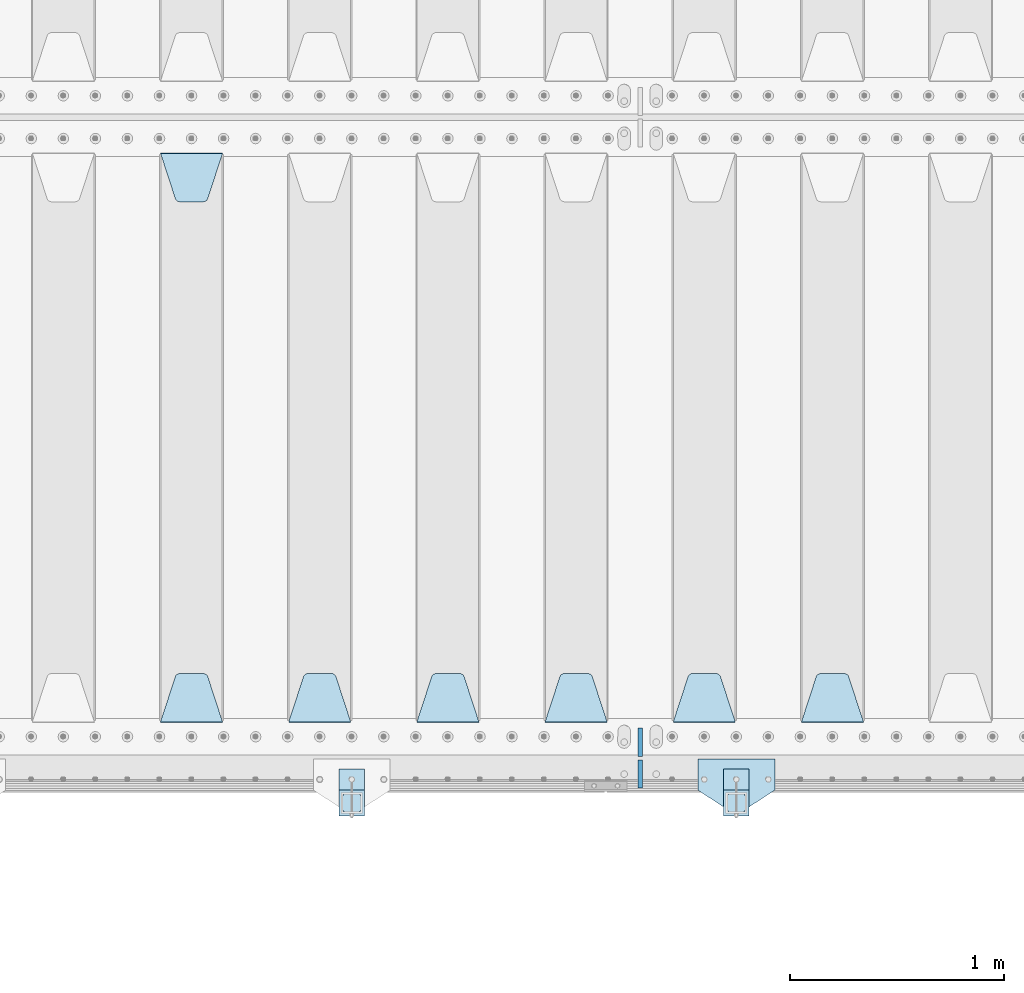
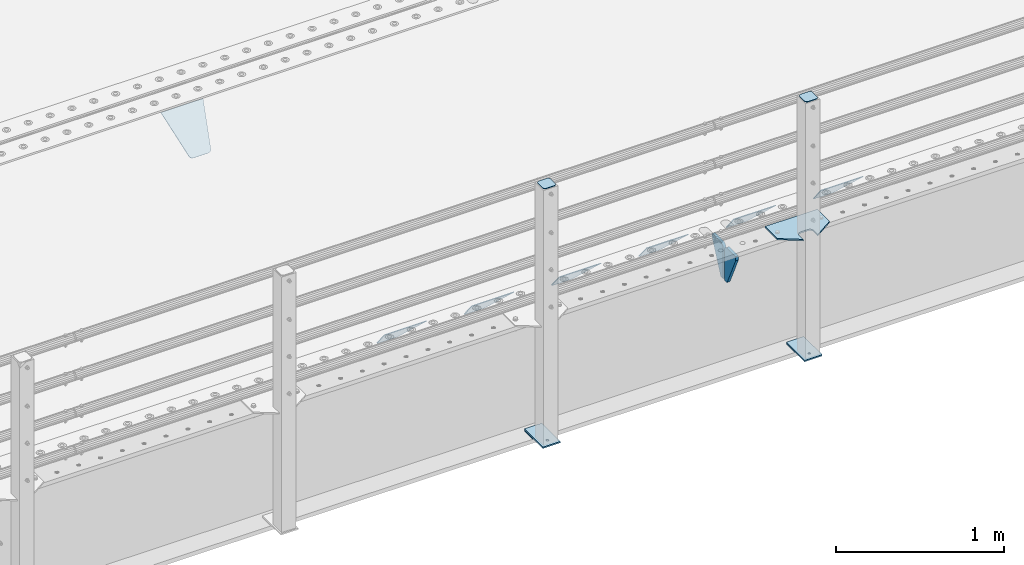
# One storey, part 204 of 257: 16 plates.
"""IFC2X3 building model written with IfcOpenShell, lengths in millimetres."""

from ifc_helpers import new_model, si_unit, frame, origin_with_axes, place, context, subcontext, project, spatial, faceted_brep, material, type_object, element, save


model = new_model("IFC2X3")

# Units and contexts
model_context = context("Model", 3, precision=1e-05, world=origin_with_axes())
body_context = subcontext(model_context, "Body", "Model", "MODEL_VIEW")
ifc_project = project(units=[si_unit("LENGTHUNIT", "METRE", prefix="MILLI"), si_unit("AREAUNIT", "SQUARE_METRE"), si_unit("VOLUMEUNIT", "CUBIC_METRE"), si_unit("MASSUNIT", "GRAM", prefix="KILO"), si_unit("TIMEUNIT", "SECOND"), si_unit("PLANEANGLEUNIT", "RADIAN"), si_unit("SOLIDANGLEUNIT", "STERADIAN"), si_unit("THERMODYNAMICTEMPERATUREUNIT", "DEGREE_CELSIUS"), si_unit("LUMINOUSINTENSITYUNIT", "LUMEN")], contexts=[model_context])

# Site, building, storey
site_placement = place(None, origin_with_axes())
site = spatial("IfcSite", under=ifc_project, at=site_placement, CompositionType="ELEMENT")
building_placement = place(site_placement, origin_with_axes())
building = spatial("IfcBuilding", under=site, at=building_placement, Name="Standard", CompositionType="ELEMENT")
storey_placement = place(building_placement, origin_with_axes())
storey = spatial("IfcBuildingStorey", under=building, at=storey_placement, Name="Undefined", CompositionType="ELEMENT", Elevation=0.0)

# Plates
ifc_material_1 = material(Name="STEEL/S355N")
plate_type_1 = type_object("IfcPlateType", PredefinedType="NOTDEFINED")
plate_1_placement = place(storey_placement, frame((48995.0, 168.232233047034, -1.76776695296758), z_axis=(0.0, 0.707106781186547, -0.707106781186548), x_axis=(-1.0, 0.0, 0.0)))
element("IfcPlate", 1, at=plate_1_placement, inside=storey, type_object=plate_type_1, material=ifc_material_1, context=body_context, shape_type="Brep", body=[
    faceted_brep([(0.0, -2.5, 0.0), (69.345504679477, -2.50000000000091, 300.17173142483), (69.345504679477, 2.5, 300.171731424831), (0.0, 2.5, 0.0), (70.927406119954, -2.50000000000091, 304.8974424154), (70.927406119954, 2.5, 304.8974424154), (73.3818627772271, -2.50000000000091, 309.234538108527), (73.3818627772271, 2.49999999999909, 309.234538108527), (76.6187032999587, -2.5, 313.023683126103), (76.6187032999587, 2.5, 313.023683126103), (80.5190132705029, -2.5, 316.125672595372), (80.5190132705029, 2.5, 316.125672595371), (84.9395038596849, -2.5, 318.426546230476), (84.9395038596849, 2.5, 318.426546230477), (89.7177759439219, -2.5, 319.841774983275), (89.7177759439219, 2.5, 319.841774983275), (94.6782862926484, -2.5, 320.319366455079), (94.6782862926484, 2.5, 320.319366455079), (195.321713707352, -2.5, 320.319366455079), (195.321713707352, 2.5, 320.319366455079), (200.282224056078, -2.5, 319.841774983275), (200.282224056078, 2.49999999999909, 319.841774983275), (205.060496140315, -2.5, 318.426546230476), (205.060496140315, 2.49999999999909, 318.426546230475), (209.480986729497, -2.5, 316.125672595371), (209.480986729497, 2.5, 316.125672595371), (213.381296700041, -2.50000000000091, 313.023683126102), (213.381296700041, 2.5, 313.023683126103), (216.618137222766, -2.50000000000091, 309.234538108527), (216.618137222766, 2.5, 309.234538108527), (219.072593880039, -2.5, 304.897442415399), (219.072593880039, 2.5, 304.897442415399), (220.654495320523, -2.50000000000091, 300.17173142483), (220.654495320523, 2.5, 300.171731424831), (290.0, -2.50000000000091, 0.0), (290.0, 2.5, 9.09494701772928e-13)], [[[0, 1, 2, 3]], [[1, 4, 5, 2]], [[4, 6, 7, 5]], [[6, 8, 9, 7]], [[8, 10, 11, 9]], [[10, 12, 13, 11]], [[12, 14, 15, 13]], [[14, 16, 17, 15]], [[16, 18, 19, 17]], [[18, 20, 21, 19]], [[20, 22, 23, 21]], [[22, 24, 25, 23]], [[24, 26, 27, 25]], [[26, 28, 29, 27]], [[28, 30, 31, 29]], [[30, 32, 33, 31]], [[32, 34, 35, 33]], [[34, 0, 3, 35]], [[5, 7, 9, 11, 13, 15, 17, 19, 21, 23, 25, 27, 29, 31, 33, 35, 3, 2]], [[34, 32, 30, 28, 26, 24, 22, 20, 18, 16, 14, 12, 10, 8, 6, 4, 1, 0]]]),
])
plate_2_placement = place(storey_placement, frame((48395.0, 168.232233047034, -1.76776695296758), z_axis=(0.0, 0.707106781186547, -0.707106781186548), x_axis=(-1.0, 0.0, 0.0)))
element("IfcPlate", 2, at=plate_2_placement, inside=storey, type_object=plate_type_1, material=ifc_material_1, context=body_context, shape_type="Brep", body=[
    faceted_brep([(0.0, -2.5, 0.0), (69.345504679477, -2.50000000000091, 300.17173142483), (69.345504679477, 2.5, 300.171731424831), (0.0, 2.5, 0.0), (70.927406119954, -2.50000000000091, 304.8974424154), (70.927406119954, 2.5, 304.8974424154), (73.3818627772271, -2.50000000000091, 309.234538108527), (73.3818627772271, 2.49999999999909, 309.234538108527), (76.6187032999587, -2.5, 313.023683126103), (76.6187032999587, 2.5, 313.023683126103), (80.5190132705029, -2.5, 316.125672595372), (80.5190132705029, 2.5, 316.125672595371), (84.9395038596849, -2.5, 318.426546230476), (84.9395038596849, 2.5, 318.426546230477), (89.7177759439219, -2.5, 319.841774983275), (89.7177759439219, 2.5, 319.841774983275), (94.6782862926484, -2.5, 320.319366455079), (94.6782862926484, 2.5, 320.319366455079), (195.321713707352, -2.5, 320.319366455079), (195.321713707352, 2.5, 320.319366455079), (200.282224056078, -2.5, 319.841774983275), (200.282224056078, 2.49999999999909, 319.841774983275), (205.060496140315, -2.5, 318.426546230476), (205.060496140315, 2.49999999999909, 318.426546230475), (209.480986729497, -2.5, 316.125672595371), (209.480986729497, 2.5, 316.125672595371), (213.381296700041, -2.50000000000091, 313.023683126102), (213.381296700041, 2.5, 313.023683126103), (216.618137222766, -2.50000000000091, 309.234538108527), (216.618137222766, 2.5, 309.234538108527), (219.072593880039, -2.5, 304.897442415399), (219.072593880039, 2.5, 304.897442415399), (220.654495320523, -2.50000000000091, 300.17173142483), (220.654495320523, 2.5, 300.171731424831), (290.0, -2.50000000000091, 0.0), (290.0, 2.5, 9.09494701772928e-13)], [[[0, 1, 2, 3]], [[1, 4, 5, 2]], [[4, 6, 7, 5]], [[6, 8, 9, 7]], [[8, 10, 11, 9]], [[10, 12, 13, 11]], [[12, 14, 15, 13]], [[14, 16, 17, 15]], [[16, 18, 19, 17]], [[18, 20, 21, 19]], [[20, 22, 23, 21]], [[22, 24, 25, 23]], [[24, 26, 27, 25]], [[26, 28, 29, 27]], [[28, 30, 31, 29]], [[30, 32, 33, 31]], [[32, 34, 35, 33]], [[34, 0, 3, 35]], [[5, 7, 9, 11, 13, 15, 17, 19, 21, 23, 25, 27, 29, 31, 33, 35, 3, 2]], [[34, 32, 30, 28, 26, 24, 22, 20, 18, 16, 14, 12, 10, 8, 6, 4, 1, 0]]]),
])
plate_3_placement = place(storey_placement, frame((47795.0, 168.232233047034, -1.76776695296758), z_axis=(0.0, 0.707106781186547, -0.707106781186548), x_axis=(-1.0, 0.0, 0.0)))
element("IfcPlate", 3, at=plate_3_placement, inside=storey, type_object=plate_type_1, material=ifc_material_1, context=body_context, shape_type="Brep", body=[
    faceted_brep([(0.0, -2.5, 0.0), (69.345504679477, -2.50000000000091, 300.17173142483), (69.345504679477, 2.5, 300.171731424831), (0.0, 2.5, 0.0), (70.927406119954, -2.50000000000091, 304.8974424154), (70.927406119954, 2.5, 304.8974424154), (73.3818627772271, -2.50000000000091, 309.234538108527), (73.3818627772271, 2.49999999999909, 309.234538108527), (76.6187032999587, -2.5, 313.023683126103), (76.6187032999587, 2.5, 313.023683126103), (80.5190132705029, -2.5, 316.125672595372), (80.5190132705029, 2.5, 316.125672595371), (84.9395038596849, -2.5, 318.426546230476), (84.9395038596849, 2.5, 318.426546230477), (89.7177759439219, -2.5, 319.841774983275), (89.7177759439219, 2.5, 319.841774983275), (94.6782862926484, -2.5, 320.319366455079), (94.6782862926484, 2.5, 320.319366455079), (195.321713707352, -2.5, 320.319366455079), (195.321713707352, 2.5, 320.319366455079), (200.282224056078, -2.5, 319.841774983275), (200.282224056078, 2.49999999999909, 319.841774983275), (205.060496140315, -2.5, 318.426546230476), (205.060496140315, 2.49999999999909, 318.426546230475), (209.480986729497, -2.5, 316.125672595371), (209.480986729497, 2.5, 316.125672595371), (213.381296700041, -2.50000000000091, 313.023683126102), (213.381296700041, 2.5, 313.023683126103), (216.618137222766, -2.50000000000091, 309.234538108527), (216.618137222766, 2.5, 309.234538108527), (219.072593880039, -2.5, 304.897442415399), (219.072593880039, 2.5, 304.897442415399), (220.654495320523, -2.50000000000091, 300.17173142483), (220.654495320523, 2.5, 300.171731424831), (290.0, -2.50000000000091, 0.0), (290.0, 2.5, 9.09494701772928e-13)], [[[0, 1, 2, 3]], [[1, 4, 5, 2]], [[4, 6, 7, 5]], [[6, 8, 9, 7]], [[8, 10, 11, 9]], [[10, 12, 13, 11]], [[12, 14, 15, 13]], [[14, 16, 17, 15]], [[16, 18, 19, 17]], [[18, 20, 21, 19]], [[20, 22, 23, 21]], [[22, 24, 25, 23]], [[24, 26, 27, 25]], [[26, 28, 29, 27]], [[28, 30, 31, 29]], [[30, 32, 33, 31]], [[32, 34, 35, 33]], [[34, 0, 3, 35]], [[5, 7, 9, 11, 13, 15, 17, 19, 21, 23, 25, 27, 29, 31, 33, 35, 3, 2]], [[34, 32, 30, 28, 26, 24, 22, 20, 18, 16, 14, 12, 10, 8, 6, 4, 1, 0]]]),
])
plate_4_placement = place(storey_placement, frame((47195.0, 168.232233047034, -1.76776695296758), z_axis=(0.0, 0.707106781186547, -0.707106781186548), x_axis=(-1.0, 0.0, 0.0)))
element("IfcPlate", 4, at=plate_4_placement, inside=storey, type_object=plate_type_1, material=ifc_material_1, context=body_context, shape_type="Brep", body=[
    faceted_brep([(0.0, -2.5, 0.0), (69.345504679477, -2.50000000000091, 300.17173142483), (69.345504679477, 2.5, 300.171731424831), (0.0, 2.5, 0.0), (70.927406119954, -2.50000000000091, 304.8974424154), (70.927406119954, 2.5, 304.8974424154), (73.3818627772271, -2.50000000000091, 309.234538108527), (73.3818627772271, 2.49999999999909, 309.234538108527), (76.6187032999587, -2.5, 313.023683126103), (76.6187032999587, 2.5, 313.023683126103), (80.5190132705029, -2.5, 316.125672595372), (80.5190132705029, 2.5, 316.125672595371), (84.9395038596849, -2.5, 318.426546230476), (84.9395038596849, 2.5, 318.426546230477), (89.7177759439219, -2.5, 319.841774983275), (89.7177759439219, 2.5, 319.841774983275), (94.6782862926484, -2.5, 320.319366455079), (94.6782862926484, 2.5, 320.319366455079), (195.321713707352, -2.5, 320.319366455079), (195.321713707352, 2.5, 320.319366455079), (200.282224056078, -2.5, 319.841774983275), (200.282224056078, 2.49999999999909, 319.841774983275), (205.060496140315, -2.5, 318.426546230476), (205.060496140315, 2.49999999999909, 318.426546230475), (209.480986729497, -2.5, 316.125672595371), (209.480986729497, 2.5, 316.125672595371), (213.381296700041, -2.50000000000091, 313.023683126102), (213.381296700041, 2.5, 313.023683126103), (216.618137222766, -2.50000000000091, 309.234538108527), (216.618137222766, 2.5, 309.234538108527), (219.072593880039, -2.5, 304.897442415399), (219.072593880039, 2.5, 304.897442415399), (220.654495320523, -2.50000000000091, 300.17173142483), (220.654495320523, 2.5, 300.171731424831), (290.0, -2.50000000000091, 0.0), (290.0, 2.5, 9.09494701772928e-13)], [[[0, 1, 2, 3]], [[1, 4, 5, 2]], [[4, 6, 7, 5]], [[6, 8, 9, 7]], [[8, 10, 11, 9]], [[10, 12, 13, 11]], [[12, 14, 15, 13]], [[14, 16, 17, 15]], [[16, 18, 19, 17]], [[18, 20, 21, 19]], [[20, 22, 23, 21]], [[22, 24, 25, 23]], [[24, 26, 27, 25]], [[26, 28, 29, 27]], [[28, 30, 31, 29]], [[30, 32, 33, 31]], [[32, 34, 35, 33]], [[34, 0, 3, 35]], [[5, 7, 9, 11, 13, 15, 17, 19, 21, 23, 25, 27, 29, 31, 33, 35, 3, 2]], [[34, 32, 30, 28, 26, 24, 22, 20, 18, 16, 14, 12, 10, 8, 6, 4, 1, 0]]]),
])
plate_5_placement = place(storey_placement, frame((46595.0, 168.232233047034, -1.76776695296758), z_axis=(0.0, 0.707106781186547, -0.707106781186548), x_axis=(-1.0, 0.0, 0.0)))
element("IfcPlate", 5, at=plate_5_placement, inside=storey, type_object=plate_type_1, material=ifc_material_1, context=body_context, shape_type="Brep", body=[
    faceted_brep([(0.0, -2.5, 0.0), (69.345504679477, -2.50000000000091, 300.17173142483), (69.345504679477, 2.5, 300.171731424831), (0.0, 2.5, 0.0), (70.927406119954, -2.50000000000091, 304.8974424154), (70.927406119954, 2.5, 304.8974424154), (73.3818627772271, -2.50000000000091, 309.234538108527), (73.3818627772271, 2.49999999999909, 309.234538108527), (76.6187032999587, -2.5, 313.023683126103), (76.6187032999587, 2.5, 313.023683126103), (80.5190132705029, -2.5, 316.125672595372), (80.5190132705029, 2.5, 316.125672595371), (84.9395038596849, -2.5, 318.426546230476), (84.9395038596849, 2.5, 318.426546230477), (89.7177759439219, -2.5, 319.841774983275), (89.7177759439219, 2.5, 319.841774983275), (94.6782862926484, -2.5, 320.319366455079), (94.6782862926484, 2.5, 320.319366455079), (195.321713707352, -2.5, 320.319366455079), (195.321713707352, 2.5, 320.319366455079), (200.282224056078, -2.5, 319.841774983275), (200.282224056078, 2.49999999999909, 319.841774983275), (205.060496140315, -2.5, 318.426546230476), (205.060496140315, 2.49999999999909, 318.426546230475), (209.480986729497, -2.5, 316.125672595371), (209.480986729497, 2.5, 316.125672595371), (213.381296700041, -2.50000000000091, 313.023683126102), (213.381296700041, 2.5, 313.023683126103), (216.618137222766, -2.50000000000091, 309.234538108527), (216.618137222766, 2.5, 309.234538108527), (219.072593880039, -2.5, 304.897442415399), (219.072593880039, 2.5, 304.897442415399), (220.654495320523, -2.50000000000091, 300.17173142483), (220.654495320523, 2.5, 300.171731424831), (290.0, -2.50000000000091, 0.0), (290.0, 2.5, 9.09494701772928e-13)], [[[0, 1, 2, 3]], [[1, 4, 5, 2]], [[4, 6, 7, 5]], [[6, 8, 9, 7]], [[8, 10, 11, 9]], [[10, 12, 13, 11]], [[12, 14, 15, 13]], [[14, 16, 17, 15]], [[16, 18, 19, 17]], [[18, 20, 21, 19]], [[20, 22, 23, 21]], [[22, 24, 25, 23]], [[24, 26, 27, 25]], [[26, 28, 29, 27]], [[28, 30, 31, 29]], [[30, 32, 33, 31]], [[32, 34, 35, 33]], [[34, 0, 3, 35]], [[5, 7, 9, 11, 13, 15, 17, 19, 21, 23, 25, 27, 29, 31, 33, 35, 3, 2]], [[34, 32, 30, 28, 26, 24, 22, 20, 18, 16, 14, 12, 10, 8, 6, 4, 1, 0]]]),
])
plate_6_placement = place(storey_placement, frame((45705.0, 2831.76776695594, -1.767766952965), z_axis=(0.0, -0.707106781186548, -0.707106781186547), x_axis=(1.0, 0.0, 0.0)))
element("IfcPlate", 6, at=plate_6_placement, inside=storey, type_object=plate_type_1, material=ifc_material_1, context=body_context, shape_type="Brep", body=[
    faceted_brep([(0.0, -2.5, 0.0), (69.345504679477, -2.50000000000091, 300.17173142483), (69.345504679477, 2.5, 300.171731424831), (0.0, 2.5, 0.0), (70.927406119954, -2.50000000000091, 304.8974424154), (70.927406119954, 2.5, 304.8974424154), (73.3818627772271, -2.50000000000091, 309.234538108527), (73.3818627772271, 2.49999999999909, 309.234538108527), (76.6187032999587, -2.5, 313.023683126103), (76.6187032999587, 2.5, 313.023683126103), (80.5190132705029, -2.5, 316.125672595372), (80.5190132705029, 2.5, 316.125672595371), (84.9395038596849, -2.5, 318.426546230476), (84.9395038596849, 2.5, 318.426546230477), (89.7177759439219, -2.5, 319.841774983275), (89.7177759439219, 2.5, 319.841774983275), (94.6782862926484, -2.5, 320.319366455079), (94.6782862926484, 2.5, 320.319366455079), (195.321713707352, -2.5, 320.319366455079), (195.321713707352, 2.5, 320.319366455079), (200.282224056078, -2.5, 319.841774983275), (200.282224056078, 2.49999999999909, 319.841774983275), (205.060496140315, -2.5, 318.426546230476), (205.060496140315, 2.49999999999909, 318.426546230475), (209.480986729497, -2.5, 316.125672595371), (209.480986729497, 2.5, 316.125672595371), (213.381296700041, -2.50000000000091, 313.023683126102), (213.381296700041, 2.5, 313.023683126103), (216.618137222766, -2.50000000000091, 309.234538108527), (216.618137222766, 2.5, 309.234538108527), (219.072593880039, -2.5, 304.897442415399), (219.072593880039, 2.5, 304.897442415399), (220.654495320523, -2.50000000000091, 300.17173142483), (220.654495320523, 2.5, 300.171731424831), (290.0, -2.50000000000091, 0.0), (290.0, 2.5, 9.09494701772928e-13)], [[[0, 1, 2, 3]], [[1, 4, 5, 2]], [[4, 6, 7, 5]], [[6, 8, 9, 7]], [[8, 10, 11, 9]], [[10, 12, 13, 11]], [[12, 14, 15, 13]], [[14, 16, 17, 15]], [[16, 18, 19, 17]], [[18, 20, 21, 19]], [[20, 22, 23, 21]], [[22, 24, 25, 23]], [[24, 26, 27, 25]], [[26, 28, 29, 27]], [[28, 30, 31, 29]], [[30, 32, 33, 31]], [[32, 34, 35, 33]], [[34, 0, 3, 35]], [[5, 7, 9, 11, 13, 15, 17, 19, 21, 23, 25, 27, 29, 31, 33, 35, 3, 2]], [[34, 32, 30, 28, 26, 24, 22, 20, 18, 16, 14, 12, 10, 8, 6, 4, 1, 0]]]),
])
plate_7_placement = place(storey_placement, frame((45995.0, 168.232233047034, -1.76776695296758), z_axis=(0.0, 0.707106781186547, -0.707106781186548), x_axis=(-1.0, 0.0, 0.0)))
element("IfcPlate", 7, at=plate_7_placement, inside=storey, type_object=plate_type_1, material=ifc_material_1, context=body_context, shape_type="Brep", body=[
    faceted_brep([(0.0, -2.5, 0.0), (69.345504679477, -2.50000000000091, 300.17173142483), (69.345504679477, 2.5, 300.171731424831), (0.0, 2.5, 0.0), (70.927406119954, -2.50000000000091, 304.8974424154), (70.927406119954, 2.5, 304.8974424154), (73.3818627772271, -2.50000000000091, 309.234538108527), (73.3818627772271, 2.49999999999909, 309.234538108527), (76.6187032999587, -2.5, 313.023683126103), (76.6187032999587, 2.5, 313.023683126103), (80.5190132705029, -2.5, 316.125672595372), (80.5190132705029, 2.5, 316.125672595371), (84.9395038596849, -2.5, 318.426546230476), (84.9395038596849, 2.5, 318.426546230477), (89.7177759439219, -2.5, 319.841774983275), (89.7177759439219, 2.5, 319.841774983275), (94.6782862926484, -2.5, 320.319366455079), (94.6782862926484, 2.5, 320.319366455079), (195.321713707352, -2.5, 320.319366455079), (195.321713707352, 2.5, 320.319366455079), (200.282224056078, -2.5, 319.841774983275), (200.282224056078, 2.49999999999909, 319.841774983275), (205.060496140315, -2.5, 318.426546230476), (205.060496140315, 2.49999999999909, 318.426546230475), (209.480986729497, -2.5, 316.125672595371), (209.480986729497, 2.5, 316.125672595371), (213.381296700041, -2.50000000000091, 313.023683126102), (213.381296700041, 2.5, 313.023683126103), (216.618137222766, -2.50000000000091, 309.234538108527), (216.618137222766, 2.5, 309.234538108527), (219.072593880039, -2.5, 304.897442415399), (219.072593880039, 2.5, 304.897442415399), (220.654495320523, -2.50000000000091, 300.17173142483), (220.654495320523, 2.5, 300.171731424831), (290.0, -2.50000000000091, 0.0), (290.0, 2.5, 9.09494701772928e-13)], [[[0, 1, 2, 3]], [[1, 4, 5, 2]], [[4, 6, 7, 5]], [[6, 8, 9, 7]], [[8, 10, 11, 9]], [[10, 12, 13, 11]], [[12, 14, 15, 13]], [[14, 16, 17, 15]], [[16, 18, 19, 17]], [[18, 20, 21, 19]], [[20, 22, 23, 21]], [[22, 24, 25, 23]], [[24, 26, 27, 25]], [[26, 28, 29, 27]], [[28, 30, 31, 29]], [[30, 32, 33, 31]], [[32, 34, 35, 33]], [[34, 0, 3, 35]], [[5, 7, 9, 11, 13, 15, 17, 19, 21, 23, 25, 27, 29, 31, 33, 35, 3, 2]], [[34, 32, 30, 28, 26, 24, 22, 20, 18, 16, 14, 12, 10, 8, 6, 4, 1, 0]]]),
])
plate_type_2 = type_object("IfcPlateType", PredefinedType="NOTDEFINED")
for number, where, z_axis, x_axis in (
    (8, (47950.0, 140.0, -30.0), (0.0, 0.0, -1.0), (0.0, -1.0, 0.0)),
    (9, (47950.0, -140.0, -30.0), (0.0, 0.0, -1.0), (0.0, 1.0, 0.0)),
):
    element("IfcPlate", number, at=place(storey_placement, frame(where, z_axis=z_axis, x_axis=x_axis)), inside=storey, type_object=plate_type_2, material=ifc_material_1, context=body_context, shape_type="Brep", body=[
        faceted_brep([(0.0, -10.0, 0.0), (0.0, -10.0, 30.0), (0.0, 10.0, 30.0), (0.0, 10.0, 0.0), (102.0, -10.0, 250.0), (102.0, 10.0, 250.0), (132.0, -10.0, 250.0), (132.0, 10.0, 250.0), (132.0, -10.0, 30.0), (132.0, 10.0, 30.0), (131.544232590366, -10.0, 24.790554669992), (131.544232590366, 10.0, 24.790554669992), (130.190778623577, -10.0, 19.7393957002299), (130.190778623577, 10.0, 19.7393957002299), (127.980762113533, -10.0, 15.0), (127.980762113533, 10.0, 15.0), (124.981333293569, -10.0, 10.7163717094038), (124.981333293569, 10.0, 10.7163717094038), (121.283628290596, -10.0, 7.01866670643062), (121.283628290596, 10.0, 7.01866670643062), (117.0, -10.0, 4.01923788646684), (117.0, 10.0, 4.01923788646684), (112.26060429977, -10.0, 1.80922137642278), (112.26060429977, 10.0, 1.80922137642278), (107.209445330008, -10.0, 0.455767409633722), (107.209445330008, 10.0, 0.455767409633722), (102.0, -10.0, 0.0), (102.0, 10.0, 0.0)], [[[0, 1, 2, 3]], [[1, 4, 5, 2]], [[4, 6, 7, 5]], [[6, 8, 9, 7]], [[8, 10, 11, 9]], [[10, 12, 13, 11]], [[12, 14, 15, 13]], [[14, 16, 17, 15]], [[16, 18, 19, 17]], [[18, 20, 21, 19]], [[20, 22, 23, 21]], [[22, 24, 25, 23]], [[24, 26, 27, 25]], [[26, 0, 3, 27]], [[5, 7, 9, 11, 13, 15, 17, 19, 21, 23, 25, 27, 3, 2]], [[26, 24, 22, 20, 18, 16, 14, 12, 10, 8, 6, 4, 1, 0]]]),
    ])
ifc_material_2 = material(Name="STEEL/S355J2")
plate_type_3 = type_object("IfcPlateType", PredefinedType="NOTDEFINED")
plate_8_placement = place(storey_placement, frame((48580.0, -4.99999999999636, 5.00000000004911), z_axis=(0.0, -1.0, 0.0), x_axis=(-1.0, 0.0, 0.0)))
element("IfcPlate", 10, at=plate_8_placement, inside=storey, type_object=plate_type_3, material=ifc_material_2, context=body_context, shape_type="Brep", body=[
    faceted_brep([(0.0, -5.0, 0.0), (2.31396552408114e-06, -5.0, 145.0), (2.31396552408114e-06, 5.0, 145.0), (0.0, 5.0, 0.0), (130.0, -5.0, 230.0), (130.0, 5.0, 230.0), (130.0, -5.0, 180.0), (130.0, 5.0, 180.0), (130.48036798992, -5.0, 175.122741949597), (130.48036798992, 5.0, 175.122741949597), (131.903011687216, -5.0, 170.432914190873), (131.903011687216, 5.0, 170.432914190873), (134.213259692435, -5.0, 166.11074417451), (134.213259692435, 5.0, 166.11074417451), (137.322330470335, -5.0, 162.322330470337), (137.322330470335, 5.0, 162.322330470337), (141.110744174512, -5.0, 159.213259692437), (141.110744174512, 5.0, 159.213259692437), (145.432914190875, -5.0, 156.903011687218), (145.432914190875, 5.0, 156.903011687218), (150.122741949599, -5.0, 155.48036798992), (150.122741949599, 5.0, 155.48036798992), (155.0, -5.0, 155.0), (155.0, 5.0, 155.0), (205.0, -5.0, 155.0), (205.0, 5.0, 155.0), (209.877258050401, -5.0, 155.48036798992), (209.877258050401, 5.0, 155.48036798992), (214.567085809125, -5.0, 156.903011687218), (214.567085809125, 5.0, 156.903011687218), (218.889255825488, -5.0, 159.213259692437), (218.889255825488, 5.0, 159.213259692437), (222.677669529665, -5.0, 162.322330470337), (222.677669529665, 5.0, 162.322330470337), (225.786740307565, -5.0, 166.11074417451), (225.786740307565, 5.0, 166.11074417451), (228.096988312784, -5.0, 170.432914190873), (228.096988312784, 5.0, 170.432914190873), (229.51963201008, -5.0, 175.122741949597), (229.51963201008, 5.0, 175.122741949597), (230.0, -5.0, 180.0), (230.0, 5.0, 180.0), (230.0, -5.0, 230.0), (230.0, 5.0, 230.0), (360.0, -5.0, 145.0), (360.0, 5.0, 145.0), (360.0, -5.0, -7.27595761418343e-12), (360.0, 5.0, -7.27595761418343e-12)], [[[0, 1, 2, 3]], [[1, 4, 5, 2]], [[4, 6, 7, 5]], [[6, 8, 9, 7]], [[8, 10, 11, 9]], [[10, 12, 13, 11]], [[12, 14, 15, 13]], [[14, 16, 17, 15]], [[16, 18, 19, 17]], [[18, 20, 21, 19]], [[20, 22, 23, 21]], [[22, 24, 25, 23]], [[24, 26, 27, 25]], [[26, 28, 29, 27]], [[28, 30, 31, 29]], [[30, 32, 33, 31]], [[32, 34, 35, 33]], [[34, 36, 37, 35]], [[36, 38, 39, 37]], [[38, 40, 41, 39]], [[40, 42, 43, 41]], [[42, 44, 45, 43]], [[44, 46, 47, 45]], [[46, 0, 3, 47]], [[5, 7, 9, 11, 13, 15, 17, 19, 21, 23, 25, 27, 29, 31, 33, 35, 37, 39, 41, 43, 45, 47, 3, 2]], [[46, 44, 42, 40, 38, 36, 34, 32, 30, 28, 26, 24, 22, 20, 18, 16, 14, 12, 10, 8, 6, 4, 1, 0]]]),
])
plate_type_4 = type_object("IfcPlateType", PredefinedType="NOTDEFINED")
for number, where, z_axis, x_axis in (
    (11, (48459.9999999999, -50.0000000002074, -850.000000000002), (0.0, -1.0, 0.0), (-1.0, 0.0, 0.0)),
    (12, (46659.9999999999, -50.0000000002074, -850.000000000002), (0.0, -1.0, 0.0), (-1.0, 0.0, 0.0)),
):
    element("IfcPlate", number, at=place(storey_placement, frame(where, z_axis=z_axis, x_axis=x_axis)), inside=storey, type_object=plate_type_4, material=ifc_material_2, context=body_context, shape_type="Brep", body=[
        faceted_brep([(53.6360389691836, -5.0, 176.363961030469), (53.6360389691836, 5.0, 176.363961030469), (59.9999999998618, 5.0, 178.999999999791), (59.9999999998618, -5.0, 178.999999999791), (66.3639610305399, 5.0, 176.363961030469), (66.3639610305399, -5.0, 176.363961030469), (68.9999999998618, 5.0, 169.999999999791), (68.9999999998618, -5.0, 169.999999999791), (66.3639610305399, 5.0, 163.636038969113), (66.3639610305399, -5.0, 163.636038969113), (59.9999999998618, 5.0, 160.999999999791), (59.9999999998618, -5.0, 160.999999999791), (53.6360389691836, 5.0, 163.636038969113), (53.6360389691836, -5.0, 163.636038969113), (50.9999999998618, 5.0, 169.999999999791), (50.9999999998618, -5.0, 169.999999999791), (120.0, -5.0, 0.0), (120.0, -5.0, 220.0), (0.0, -5.0, 220.0), (0.0, -5.0, 0.0), (0.0, 5.0, 0.0), (120.0, 5.0, 0.0), (120.0, 5.0, 220.0), (0.0, 5.0, 220.0)], [[[0, 1, 2, 3]], [[3, 2, 4, 5]], [[5, 4, 6, 7]], [[7, 6, 8, 9]], [[9, 8, 10, 11]], [[11, 10, 12, 13]], [[13, 12, 14, 15]], [[15, 14, 1, 0]], [[16, 17, 18, 19], [11, 13, 15, 0, 3, 5, 7, 9]], [[16, 19, 20, 21]], [[17, 16, 21, 22]], [[18, 17, 22, 23]], [[19, 18, 23, 20]], [[22, 21, 20, 23], [2, 1, 14, 12, 10, 8, 6, 4]]]),
    ])
plate_type_5 = type_object("IfcPlateType", PredefinedType="NOTDEFINED")
plate_9_placement = place(storey_placement, frame((48355.9999999999, -166.000000000207, 1012.50000000001), z_axis=(0.0, -1.0, 0.0), x_axis=(1.0, 0.0, 0.0)))
element("IfcPlate", 13, at=plate_9_placement, inside=storey, type_object=plate_type_5, material=ifc_material_2, context=body_context, shape_type="Brep", body=[
    faceted_brep([(0.0, -2.5, 19.0), (0.0, -2.5, 69.0), (0.0, 2.5, 69.0), (0.0, 2.5, 19.0), (0.476369668547704, -2.5, 73.2278977451697), (0.476369668547704, 2.5, 73.2278977451697), (1.88159150985302, -2.5, 77.2437910432327), (1.88159150985302, 2.5, 77.2437910432327), (4.14520183311106, -2.5, 80.8463062353167), (4.14520183311106, 2.5, 80.8463062353167), (7.15369376468152, -2.5, 83.8547981668926), (7.15369376468152, 2.5, 83.8547981668926), (10.7562089567655, -2.5, 86.1184084901452), (10.7562089567655, 2.5, 86.1184084901452), (14.7721022548285, -2.5, 87.5236303314541), (14.7721022548285, 2.5, 87.5236303314541), (19.0, -2.5, 88.0), (19.0, 2.5, 88.0), (69.0, -2.5, 88.0), (69.0, 2.5, 88.0), (73.2278977451715, -2.5, 87.5236303314541), (73.2278977451715, 2.5, 87.5236303314541), (77.2437910432345, -2.5, 86.1184084901452), (77.2437910432345, 2.5, 86.1184084901452), (80.8463062353185, -2.5, 83.8547981668926), (80.8463062353185, 2.5, 83.8547981668926), (83.8547981668889, -2.5, 80.8463062353167), (83.8547981668889, 2.5, 80.8463062353167), (86.118408490147, -2.5, 77.2437910432327), (86.118408490147, 2.5, 77.2437910432327), (87.5236303314523, -2.5, 73.2278977451697), (87.5236303314523, 2.5, 73.2278977451697), (88.0, -2.5, 69.0), (88.0, 2.5, 69.0), (88.0, -2.5, 19.0), (88.0, 2.5, 19.0), (87.5236303314523, -2.5, 14.7721022548303), (87.5236303314523, 2.5, 14.7721022548303), (86.118408490147, -2.5, 10.7562089567673), (86.118408490147, 2.5, 10.7562089567673), (83.8547981668889, -2.5, 7.15369376468334), (83.8547981668889, 2.5, 7.15369376468334), (80.8463062353185, -2.5, 4.14520183310742), (80.8463062353185, 2.5, 4.14520183310742), (77.2437910432345, -2.5, 1.88159150985484), (77.2437910432345, 2.5, 1.88159150985484), (73.2278977451715, -2.5, 0.476369668545885), (73.2278977451715, 2.5, 0.476369668545885), (69.0, -2.5, 0.0), (69.0, 2.5, 0.0), (19.0, -2.5, 0.0), (19.0, 2.5, 0.0), (14.7721022548285, -2.5, 0.476369668545885), (14.7721022548285, 2.5, 0.476369668545885), (10.7562089567655, -2.5, 1.88159150985484), (10.7562089567655, 2.5, 1.88159150985484), (7.15369376468152, -2.5, 4.14520183310742), (7.15369376468152, 2.5, 4.14520183310742), (4.14520183311106, -2.5, 7.15369376468334), (4.14520183311106, 2.5, 7.15369376468334), (1.88159150985302, -2.5, 10.7562089567673), (1.88159150985302, 2.5, 10.7562089567673), (0.476369668547704, -2.5, 14.7721022548303), (0.476369668547704, 2.5, 14.7721022548303)], [[[0, 1, 2, 3]], [[1, 4, 5, 2]], [[4, 6, 7, 5]], [[6, 8, 9, 7]], [[8, 10, 11, 9]], [[10, 12, 13, 11]], [[12, 14, 15, 13]], [[14, 16, 17, 15]], [[16, 18, 19, 17]], [[18, 20, 21, 19]], [[20, 22, 23, 21]], [[22, 24, 25, 23]], [[24, 26, 27, 25]], [[26, 28, 29, 27]], [[28, 30, 31, 29]], [[30, 32, 33, 31]], [[32, 34, 35, 33]], [[34, 36, 37, 35]], [[36, 38, 39, 37]], [[38, 40, 41, 39]], [[40, 42, 43, 41]], [[42, 44, 45, 43]], [[44, 46, 47, 45]], [[46, 48, 49, 47]], [[48, 50, 51, 49]], [[50, 52, 53, 51]], [[52, 54, 55, 53]], [[54, 56, 57, 55]], [[56, 58, 59, 57]], [[58, 60, 61, 59]], [[60, 62, 63, 61]], [[62, 0, 3, 63]], [[5, 7, 9, 11, 13, 15, 17, 19, 21, 23, 25, 27, 29, 31, 33, 35, 37, 39, 41, 43, 45, 47, 49, 51, 53, 55, 57, 59, 61, 63, 3, 2]], [[62, 60, 58, 56, 54, 52, 50, 48, 46, 44, 42, 40, 38, 36, 34, 32, 30, 28, 26, 24, 22, 20, 18, 16, 14, 12, 10, 8, 6, 4, 1, 0]]]),
])
plate_10_placement = place(storey_placement, frame((46555.9999999999, -166.000000000207, 1012.50000000001), z_axis=(0.0, -1.0, 0.0), x_axis=(1.0, 0.0, 0.0)))
element("IfcPlate", 14, at=plate_10_placement, inside=storey, type_object=plate_type_5, material=ifc_material_2, context=body_context, shape_type="Brep", body=[
    faceted_brep([(0.0, -2.5, 19.0), (0.0, -2.5, 69.0), (0.0, 2.5, 69.0), (0.0, 2.5, 19.0), (0.476369668547704, -2.5, 73.2278977451697), (0.476369668547704, 2.5, 73.2278977451697), (1.88159150985302, -2.5, 77.2437910432327), (1.88159150985302, 2.5, 77.2437910432327), (4.14520183311106, -2.5, 80.8463062353167), (4.14520183311106, 2.5, 80.8463062353167), (7.15369376468152, -2.5, 83.8547981668926), (7.15369376468152, 2.5, 83.8547981668926), (10.7562089567655, -2.5, 86.1184084901452), (10.7562089567655, 2.5, 86.1184084901452), (14.7721022548285, -2.5, 87.5236303314541), (14.7721022548285, 2.5, 87.5236303314541), (19.0, -2.5, 88.0), (19.0, 2.5, 88.0), (69.0, -2.5, 88.0), (69.0, 2.5, 88.0), (73.2278977451715, -2.5, 87.5236303314541), (73.2278977451715, 2.5, 87.5236303314541), (77.2437910432345, -2.5, 86.1184084901452), (77.2437910432345, 2.5, 86.1184084901452), (80.8463062353185, -2.5, 83.8547981668926), (80.8463062353185, 2.5, 83.8547981668926), (83.8547981668889, -2.5, 80.8463062353167), (83.8547981668889, 2.5, 80.8463062353167), (86.118408490147, -2.5, 77.2437910432327), (86.118408490147, 2.5, 77.2437910432327), (87.5236303314523, -2.5, 73.2278977451697), (87.5236303314523, 2.5, 73.2278977451697), (88.0, -2.5, 69.0), (88.0, 2.5, 69.0), (88.0, -2.5, 19.0), (88.0, 2.5, 19.0), (87.5236303314523, -2.5, 14.7721022548303), (87.5236303314523, 2.5, 14.7721022548303), (86.118408490147, -2.5, 10.7562089567673), (86.118408490147, 2.5, 10.7562089567673), (83.8547981668889, -2.5, 7.15369376468334), (83.8547981668889, 2.5, 7.15369376468334), (80.8463062353185, -2.5, 4.14520183310742), (80.8463062353185, 2.5, 4.14520183310742), (77.2437910432345, -2.5, 1.88159150985484), (77.2437910432345, 2.5, 1.88159150985484), (73.2278977451715, -2.5, 0.476369668545885), (73.2278977451715, 2.5, 0.476369668545885), (69.0, -2.5, 0.0), (69.0, 2.5, 0.0), (19.0, -2.5, 0.0), (19.0, 2.5, 0.0), (14.7721022548285, -2.5, 0.476369668545885), (14.7721022548285, 2.5, 0.476369668545885), (10.7562089567655, -2.5, 1.88159150985484), (10.7562089567655, 2.5, 1.88159150985484), (7.15369376468152, -2.5, 4.14520183310742), (7.15369376468152, 2.5, 4.14520183310742), (4.14520183311106, -2.5, 7.15369376468334), (4.14520183311106, 2.5, 7.15369376468334), (1.88159150985302, -2.5, 10.7562089567673), (1.88159150985302, 2.5, 10.7562089567673), (0.476369668547704, -2.5, 14.7721022548303), (0.476369668547704, 2.5, 14.7721022548303)], [[[0, 1, 2, 3]], [[1, 4, 5, 2]], [[4, 6, 7, 5]], [[6, 8, 9, 7]], [[8, 10, 11, 9]], [[10, 12, 13, 11]], [[12, 14, 15, 13]], [[14, 16, 17, 15]], [[16, 18, 19, 17]], [[18, 20, 21, 19]], [[20, 22, 23, 21]], [[22, 24, 25, 23]], [[24, 26, 27, 25]], [[26, 28, 29, 27]], [[28, 30, 31, 29]], [[30, 32, 33, 31]], [[32, 34, 35, 33]], [[34, 36, 37, 35]], [[36, 38, 39, 37]], [[38, 40, 41, 39]], [[40, 42, 43, 41]], [[42, 44, 45, 43]], [[44, 46, 47, 45]], [[46, 48, 49, 47]], [[48, 50, 51, 49]], [[50, 52, 53, 51]], [[52, 54, 55, 53]], [[54, 56, 57, 55]], [[56, 58, 59, 57]], [[58, 60, 61, 59]], [[60, 62, 63, 61]], [[62, 0, 3, 63]], [[5, 7, 9, 11, 13, 15, 17, 19, 21, 23, 25, 27, 29, 31, 33, 35, 37, 39, 41, 43, 45, 47, 49, 51, 53, 55, 57, 59, 61, 63, 3, 2]], [[62, 60, 58, 56, 54, 52, 50, 48, 46, 44, 42, 40, 38, 36, 34, 32, 30, 28, 26, 24, 22, 20, 18, 16, 14, 12, 10, 8, 6, 4, 1, 0]]]),
])
plate_type_6 = type_object("IfcPlateType", PredefinedType="NOTDEFINED")
for number, where, z_axis, x_axis in (
    (15, (48459.9999999999, -50.0000000002074, -857.500000000002), (0.0, -1.0, 0.0), (-1.0, 0.0, 0.0)),
    (16, (46659.9999999999, -50.0000000002074, -857.500000000002), (0.0, -1.0, 0.0), (-1.0, 0.0, 0.0)),
):
    element("IfcPlate", number, at=place(storey_placement, frame(where, z_axis=z_axis, x_axis=x_axis)), inside=storey, type_object=plate_type_6, material=ifc_material_2, context=body_context, shape_type="Brep", body=[
        faceted_brep([(0.0, -2.5, 0.0), (0.0, -2.5, 100.0), (0.0, 2.5, 100.0), (0.0, 2.5, 0.0), (120.0, -2.5, 100.0), (120.0, 2.5, 100.0), (120.0, -2.5, 0.0), (120.0, 2.5, 0.0)], [[[0, 1, 2, 3]], [[1, 4, 5, 2]], [[4, 6, 7, 5]], [[6, 0, 3, 7]], [[5, 7, 3, 2]], [[6, 4, 1, 0]]]),
    ])

save(model, "model.ifc")
